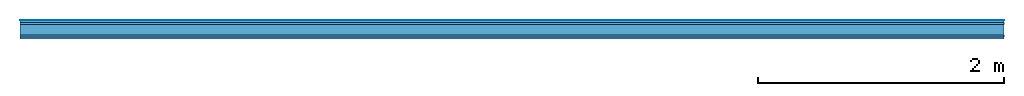
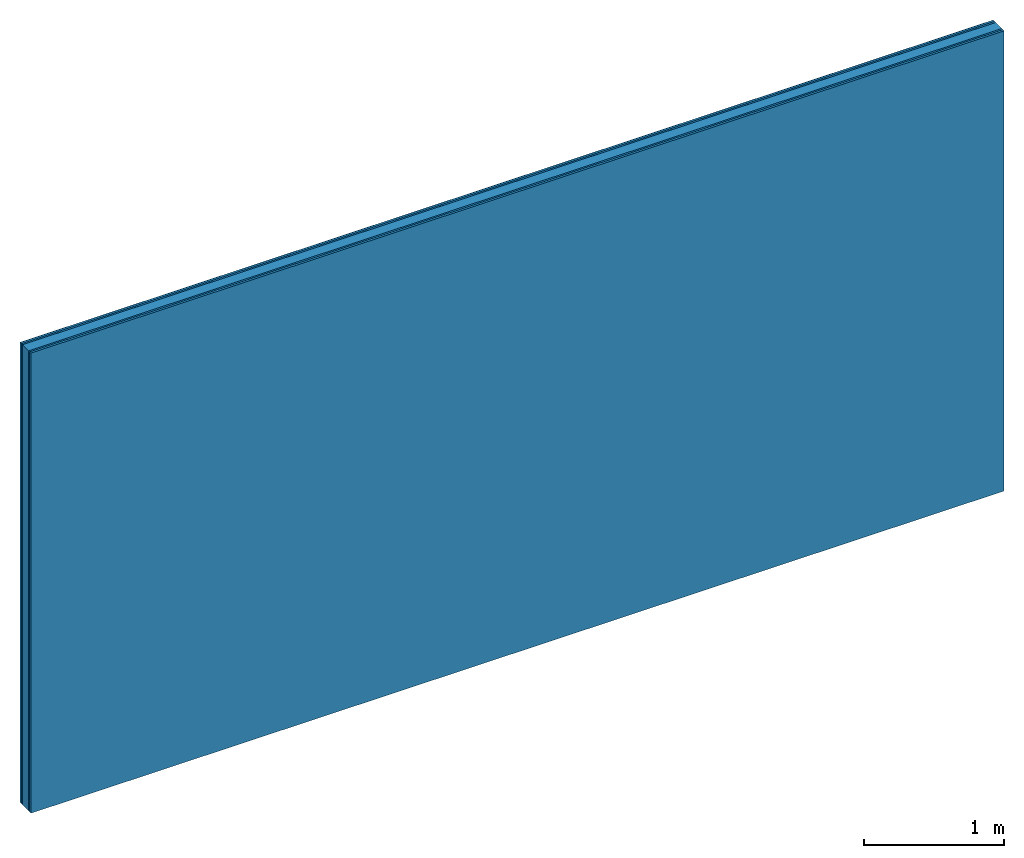
# One storey: 5 plates, 1 member, 1 element without a shape of its own.
"""IFC4 building model written with IfcOpenShell, lengths in metres."""

from ifc_helpers import new_model, si_unit, derived_unit, direction, frame, frame_2d, origin, origin_with_axes, place, context, project, spatial, rectangle, extrude, material, layer, layer_set, type_object, element, aggregate, save


model = new_model("IFC4")

# Units and contexts
plan_context = context("Plan", 3, precision=1e-05, world=origin(), true_north=direction((0.0, 1.0)))
model_context = context("Model", 3, precision=1e-05, world=origin(), true_north=direction((0.0, 1.0)))
ifc_project = project(units=[si_unit("LENGTHUNIT", "METRE"), derived_unit("SOUNDPRESSUREUNIT", [(si_unit("PRESSUREUNIT", "PASCAL", prefix="MICRO"), 0)]), si_unit("ENERGYUNIT", "JOULE", prefix="MEGA"), si_unit("MASSUNIT", "GRAM", prefix="KILO"), derived_unit("THERMALTRANSMITTANCEUNIT", [(si_unit("POWERUNIT", "WATT"), 1), (si_unit("AREAUNIT", "SQUARE_METRE"), -1), (si_unit("THERMODYNAMICTEMPERATUREUNIT", "KELVIN"), -1)]), derived_unit("AREADENSITYUNIT", [(si_unit("MASSUNIT", "GRAM", prefix="KILO"), 1), (si_unit("AREAUNIT", "SQUARE_METRE"), -1)]), derived_unit("USERDEFINED", [(si_unit("ENERGYUNIT", "JOULE", prefix="MEGA"), 1), (si_unit("AREAUNIT", "SQUARE_METRE"), -1)])], contexts=[plan_context, model_context])

# Site, building, storey
site = spatial("IfcSite", under=ifc_project)
building_placement = place(None, origin())
building = spatial("IfcBuilding", under=site, at=building_placement)
storey_placement = place(building_placement, origin())
storey = spatial("IfcBuildingStorey", under=building, at=storey_placement)

# Wall, member, plates
ifc_material_1 = material(Category="04.001")
ifc_layer_1 = layer(ifc_material_1, 0.003, Name="Surface")
ifc_material_2 = material(Category="03.007")
ifc_layer_2 = layer(ifc_material_2, 0.018, Name="2nd layer")
ifc_layer_3 = layer(ifc_material_2, 0.015, Name="1st layer")
ifc_material_3 = material(Name="of the art")
ifc_layer_4 = layer(ifc_material_3, 0.0, Name="Bond")
ifc_layer_5 = layer(None, 0.087, Name="Support")
ifc_layer_6 = layer(ifc_material_3, 0.0, Name="Bond")
ifc_layer_7 = layer(ifc_material_2, 0.015, Name="1st layer")
ifc_layer_8 = layer(ifc_material_2, 0.018, Name="2nd layer")
ifc_layer_set = layer_set([ifc_layer_1, ifc_layer_2, ifc_layer_3, ifc_layer_4, ifc_layer_5, ifc_layer_6, ifc_layer_7, ifc_layer_8])
wall_type = type_object("IfcWallType", Name="C0432", PredefinedType="NOTDEFINED", material=ifc_layer_set)
wall_placement = place(None, frame((0.0, 0.0, 0.0), z_axis=(0.0, -1.0, 0.0), x_axis=(1.0, 0.0, 0.0)))
wall = element("IfcWall", 1, at=wall_placement, inside=storey, type_object=wall_type, material=ifc_layer_set, Name="Wall #1")
ifc_material_4 = material(Name="Solid timber panel")
member_placement = place(wall_placement, origin())
member = element("IfcMember", 2, at=member_placement, material=ifc_material_4, Name="Support", context=plan_context, shape_type="SweptSolid", body=[
    extrude(rectangle(XDim=1.0, YDim=0.087, at=frame_2d((0.5, 0.0435), x_axis=(1.0, 0.0))), frame((0.0, 4.0, 0.036), z_axis=(0.0, -1.0, 0.0), x_axis=(1.0, 0.0, 0.0)), (0.0, 0.0, 1.0), 4.0),
    extrude(rectangle(XDim=1.0, YDim=0.087, at=frame_2d((0.5, 0.0435), x_axis=(1.0, 0.0))), frame((1.0, 4.0, 0.036), z_axis=(0.0, -1.0, 0.0), x_axis=(1.0, 0.0, 0.0)), (0.0, 0.0, 1.0), 4.0),
    extrude(rectangle(XDim=1.0, YDim=0.087, at=frame_2d((0.5, 0.0435), x_axis=(1.0, 0.0))), frame((2.0, 4.0, 0.036), z_axis=(0.0, -1.0, 0.0), x_axis=(1.0, 0.0, 0.0)), (0.0, 0.0, 1.0), 4.0),
    extrude(rectangle(XDim=1.0, YDim=0.087, at=frame_2d((0.5, 0.0435), x_axis=(1.0, 0.0))), frame((3.0, 4.0, 0.036), z_axis=(0.0, -1.0, 0.0), x_axis=(1.0, 0.0, 0.0)), (0.0, 0.0, 1.0), 4.0),
    extrude(rectangle(XDim=1.0, YDim=0.087, at=frame_2d((0.5, 0.0435), x_axis=(1.0, 0.0))), frame((4.0, 4.0, 0.036), z_axis=(0.0, -1.0, 0.0), x_axis=(1.0, 0.0, 0.0)), (0.0, 0.0, 1.0), 4.0),
    extrude(rectangle(XDim=1.0, YDim=0.087, at=frame_2d((0.5, 0.0435), x_axis=(1.0, 0.0))), frame((5.0, 4.0, 0.036), z_axis=(0.0, -1.0, 0.0), x_axis=(1.0, 0.0, 0.0)), (0.0, 0.0, 1.0), 4.0),
    extrude(rectangle(XDim=1.0, YDim=0.087, at=frame_2d((0.5, 0.0435), x_axis=(1.0, 0.0))), frame((6.0, 4.0, 0.036), z_axis=(0.0, -1.0, 0.0), x_axis=(1.0, 0.0, 0.0)), (0.0, 0.0, 1.0), 4.0),
    extrude(rectangle(XDim=1.0, YDim=0.087, at=frame_2d((0.5, 0.0435), x_axis=(1.0, 0.0))), frame((7.0, 4.0, 0.036), z_axis=(0.0, -1.0, 0.0), x_axis=(1.0, 0.0, 0.0)), (0.0, 0.0, 1.0), 4.0),
])
plate_1_placement = place(wall_placement, origin())
plate_1 = element("IfcPlate", 3, at=plate_1_placement, material=ifc_material_1, Name="Surface", context=plan_context, shape_type="SweptSolid", body=[
    extrude(rectangle(XDim=8.0, YDim=4.0, at=frame_2d((4.0, 2.0), x_axis=(1.0, 0.0))), origin_with_axes(), (0.0, 0.0, 1.0), 0.003),
])
plate_2_placement = place(wall_placement, origin())
plate_2 = element("IfcPlate", 4, at=plate_2_placement, material=ifc_material_2, Name="2nd layer", context=plan_context, shape_type="SweptSolid", body=[
    extrude(rectangle(XDim=8.0, YDim=4.0, at=frame_2d((4.0, 2.0), x_axis=(1.0, 0.0))), frame((0.0, 0.0, 0.003), z_axis=(0.0, 0.0, 1.0), x_axis=(1.0, 0.0, 0.0)), (0.0, 0.0, 1.0), 0.018),
])
plate_3_placement = place(wall_placement, origin())
plate_3 = element("IfcPlate", 5, at=plate_3_placement, material=ifc_material_2, Name="1st layer", context=plan_context, shape_type="SweptSolid", body=[
    extrude(rectangle(XDim=8.0, YDim=4.0, at=frame_2d((4.0, 2.0), x_axis=(1.0, 0.0))), frame((0.0, 0.0, 0.021), z_axis=(0.0, 0.0, 1.0), x_axis=(1.0, 0.0, 0.0)), (0.0, 0.0, 1.0), 0.015),
])
plate_4_placement = place(wall_placement, origin())
plate_4 = element("IfcPlate", 6, at=plate_4_placement, material=ifc_material_2, Name="1st layer", context=plan_context, shape_type="SweptSolid", body=[
    extrude(rectangle(XDim=8.0, YDim=4.0, at=frame_2d((4.0, 2.0), x_axis=(1.0, 0.0))), frame((0.0, 0.0, 0.123), z_axis=(0.0, 0.0, 1.0), x_axis=(1.0, 0.0, 0.0)), (0.0, 0.0, 1.0), 0.015),
])
plate_5_placement = place(wall_placement, origin())
plate_5 = element("IfcPlate", 7, at=plate_5_placement, material=ifc_material_2, Name="2nd layer", context=plan_context, shape_type="SweptSolid", body=[
    extrude(rectangle(XDim=8.0, YDim=4.0, at=frame_2d((4.0, 2.0), x_axis=(1.0, 0.0))), frame((0.0, 0.0, 0.138), z_axis=(0.0, 0.0, 1.0), x_axis=(1.0, 0.0, 0.0)), (0.0, 0.0, 1.0), 0.018),
])
aggregate(wall, [plate_1, plate_2, plate_3, member, plate_4, plate_5])

save(model, "model.ifc")
